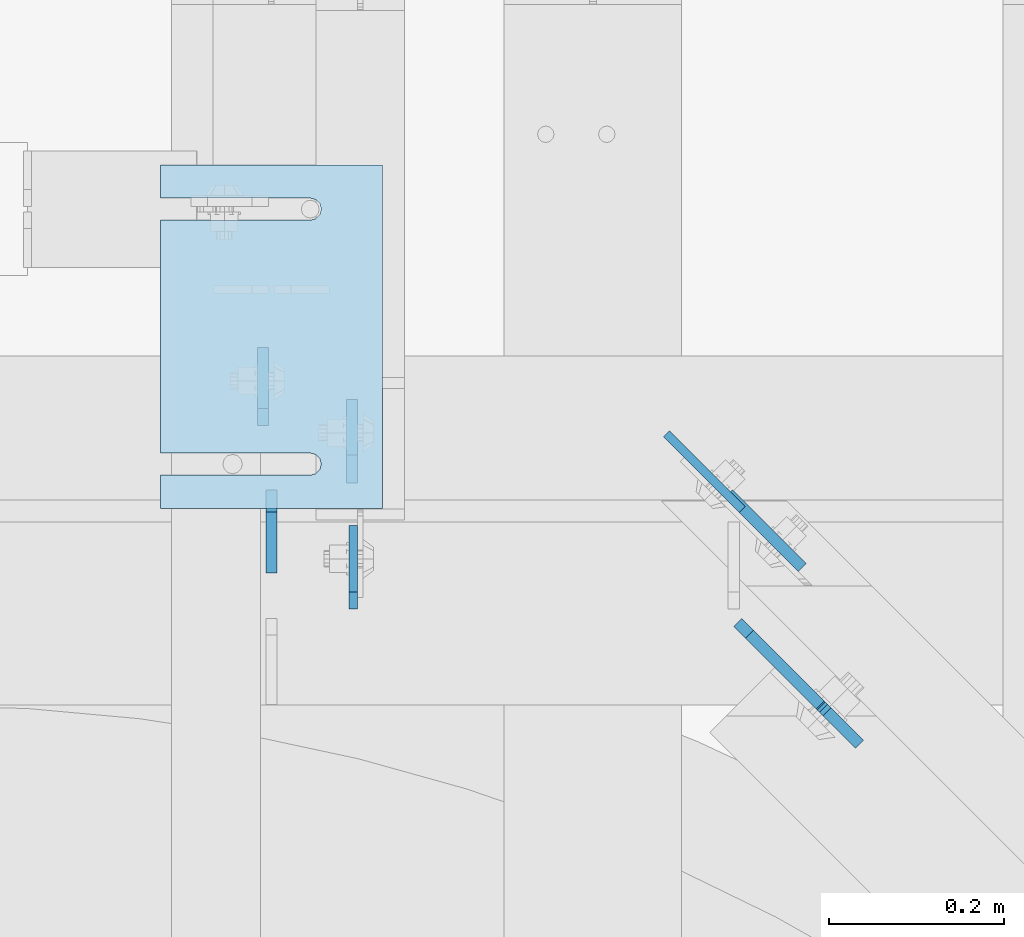
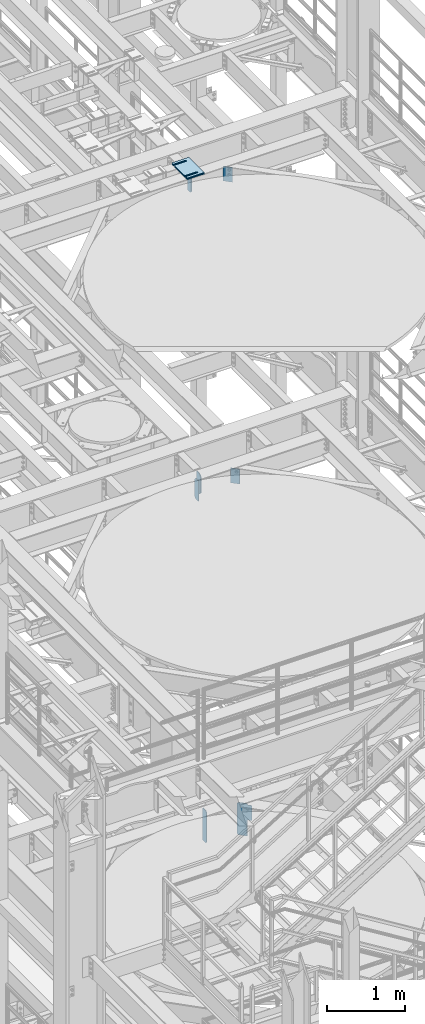
# One storey, part 1575 of 1876: 13 plates, 9 elements without a shape of their own.
"""IFC2X3 building model written with IfcOpenShell, lengths in millimetres."""

from ifc_helpers import new_model, si_unit, frame, origin_with_axes, place, context, subcontext, project, spatial, faceted_brep, material, type_object, element, aggregate, save


model = new_model("IFC2X3")

# Units and contexts
model_context = context("Model", 3, precision=1e-05, world=origin_with_axes())
body_context = subcontext(model_context, "Body", "Model", "MODEL_VIEW")
ifc_project = project(units=[si_unit("LENGTHUNIT", "METRE", prefix="MILLI"), si_unit("AREAUNIT", "SQUARE_METRE"), si_unit("VOLUMEUNIT", "CUBIC_METRE"), si_unit("MASSUNIT", "GRAM", prefix="KILO"), si_unit("TIMEUNIT", "SECOND"), si_unit("PLANEANGLEUNIT", "RADIAN"), si_unit("SOLIDANGLEUNIT", "STERADIAN"), si_unit("THERMODYNAMICTEMPERATUREUNIT", "DEGREE_CELSIUS"), si_unit("LUMINOUSINTENSITYUNIT", "LUMEN")], contexts=[model_context])

# Site, building, storey
site_placement = place(None, origin_with_axes())
site = spatial("IfcSite", under=ifc_project, at=site_placement, CompositionType="ELEMENT")
building_placement = place(site_placement, origin_with_axes())
building = spatial("IfcBuilding", under=site, at=building_placement, Name="Undefined", CompositionType="ELEMENT")
storey_placement = place(building_placement, origin_with_axes())
storey = spatial("IfcBuildingStorey", under=building, at=storey_placement, Name="Undefined", CompositionType="ELEMENT", Elevation=0.0)

# Assembly, plate
assembly_1_placement = place(storey_placement, origin_with_axes())
assembly_1 = element("IfcElementAssembly", 1, at=assembly_1_placement, inside=storey, Name="BEAM", AssemblyPlace="NOTDEFINED", PredefinedType="RIGID_FRAME")
ifc_material = material(Name="STEEL/A36")
plate_type_1 = type_object("IfcPlateType", PredefinedType="NOTDEFINED")
plate_1_placement = place(assembly_1_placement, frame((4919.66200008392, 704.254688, 7635.875), z_axis=(0.0, 0.0, 1.0), x_axis=(0.0, 1.0, 0.0)))
plate_1 = element("IfcPlate", 2, at=plate_1_placement, type_object=plate_type_1, material=ifc_material, Name="PLATE", context=body_context, shape_type="Brep", body=[
    faceted_brep([(0.0, -4.76249999999982, 19.0499992370605), (0.0, -4.76249999999982, 481.012500762939), (0.0, 4.76249999999982, 481.012500762939), (0.0, 4.76249999999982, 19.0499992370605), (19.0499992370605, -4.76249999999982, 500.0625), (19.0499992370605, 4.76249999999982, 500.0625), (95.25, -4.76249999999982, 500.0625), (95.25, 4.76249999999982, 500.0625), (95.25, -4.76249999999982, 0.0), (95.25, 4.76249999999982, 0.0), (19.0499992370605, -4.76249999999982, 0.0), (19.0499992370605, 4.76249999999982, 0.0)], [[[0, 1, 2, 3]], [[1, 4, 5, 2]], [[4, 6, 7, 5]], [[6, 8, 9, 7]], [[8, 10, 11, 9]], [[10, 0, 3, 11]], [[5, 7, 9, 11, 3, 2]], [[10, 8, 6, 4, 1, 0]]]),
])

assembly_2_placement = place(storey_placement, origin_with_axes())
assembly_2 = element("IfcElementAssembly", 3, at=assembly_2_placement, inside=storey, Name="BEAM", AssemblyPlace="NOTDEFINED", PredefinedType="RIGID_FRAME")
plate_type_2 = type_object("IfcPlateType", PredefinedType="NOTDEFINED")
plate_2_placement = place(assembly_2_placement, frame((4816.47517775661, 914.399999999455, 17681.575), z_axis=(0.0, 0.0, 1.0), x_axis=(0.0, 1.0, 0.0)))
plate_2 = element("IfcPlate", 4, at=plate_2_placement, type_object=plate_type_2, material=ifc_material, Name="PLATE", context=body_context, shape_type="Brep", body=[
    faceted_brep([(0.0, -6.35000000000196, 19.0499992370605), (0.0, -6.35000000000036, 271.462512969971), (0.0, 6.35000000000036, 271.462512969971), (0.0, 6.35000000000105, 19.0499992370605), (19.0499992370605, -6.35000000000036, 290.512512207031), (19.0499992370605, 6.35000000000036, 290.512512207031), (88.9000015258789, -6.35000000000036, 290.512512207031), (88.9000015258789, 6.35000000000036, 290.512512207031), (88.9000015258789, -6.34999999999991, 0.0), (88.9000015258789, 6.34999999999991, 0.0), (19.0499992370642, -6.35000000000105, 0.0), (19.0499992370633, 6.35000000000105, 0.0)], [[[0, 1, 2, 3]], [[1, 4, 5, 2]], [[4, 6, 7, 5]], [[6, 8, 9, 7]], [[8, 10, 11, 9]], [[10, 0, 3, 11]], [[5, 7, 9, 11, 3, 2]], [[10, 8, 6, 4, 1, 0]]]),
])

# Assembly, plates
assembly_3_placement = place(storey_placement, origin_with_axes())
assembly_3 = element("IfcElementAssembly", 5, at=assembly_3_placement, inside=storey, Name="BEAM", AssemblyPlace="NOTDEFINED", PredefinedType="RIGID_FRAME")
plate_type_3 = type_object("IfcPlateType", PredefinedType="NOTDEFINED")
plate_3_placement = place(assembly_3_placement, frame((4826.0, 745.33125, 12976.225), z_axis=(0.0, 0.0, 1.0), x_axis=(0.0, 1.0, 0.0)))
plate_3 = element("IfcPlate", 6, at=plate_3_placement, type_object=plate_type_3, material=ifc_material, Name="PLATE", context=body_context, shape_type="Brep", body=[
    faceted_brep([(0.0, -6.35000000000036, 0.0), (1.81898940354586e-12, -6.35000000000127, 317.5), (0.0, 6.35000000000036, 317.5), (0.0, 6.35000000000036, 0.0), (69.8500003814697, -6.34999999999991, 317.5), (69.8500003814697, 6.34999999999991, 317.5), (95.25, -6.34999999999991, 292.10000038147), (95.25, 6.34999999999991, 292.10000038147), (95.25, -6.34999999999991, 25.3999996185303), (95.25, 6.34999999999991, 25.3999996185303), (69.8500003814697, -6.34999999999991, 0.0), (69.8500003814697, 6.34999999999991, 0.0)], [[[0, 1, 2, 3]], [[1, 4, 5, 2]], [[4, 6, 7, 5]], [[6, 8, 9, 7]], [[8, 10, 11, 9]], [[10, 0, 3, 11]], [[5, 7, 9, 11, 3, 2]], [[10, 8, 6, 4, 1, 0]]]),
])
plate_4_placement = place(assembly_3_placement, frame((4918.07499990463, 848.51875, 12977.8125), z_axis=(0.0, 0.0, 1.0), x_axis=(0.0, 1.0, 0.0)))
plate_4 = element("IfcPlate", 7, at=plate_4_placement, type_object=plate_type_3, material=ifc_material, Name="PLATE", context=body_context, shape_type="Brep", body=[
    faceted_brep([(0.0, -6.34999999999991, 31.75), (-1.81898940354586e-12, -6.34999999999991, 284.162506103516), (1.81898940354586e-12, 6.35000000000173, 284.162506103516), (0.0, 6.34999999999991, 31.75), (31.7499999999927, -6.34999999999991, 315.912506103516), (31.7499999999982, 6.35000000000309, 315.912506103516), (95.25, -6.35000000000036, 315.912506103516), (95.25, 6.35000000000036, 315.912506103516), (95.25, -6.35000000000036, 0.0), (95.25, 6.35000000000036, 0.0), (31.75, -6.34999999999991, 0.0), (31.75, 6.34999999999991, 0.0)], [[[0, 1, 2, 3]], [[1, 4, 5, 2]], [[4, 6, 7, 5]], [[6, 8, 9, 7]], [[8, 10, 11, 9]], [[10, 0, 3, 11]], [[5, 7, 9, 11, 3, 2]], [[10, 8, 6, 4, 1, 0]]]),
])

# Plate
plate_type_4 = type_object("IfcPlateType", PredefinedType="NOTDEFINED")
plate_5_placement = place(assembly_1_placement, frame((5360.09011090052, 688.652059174589, 7653.3375), z_axis=(0.500000083934032, -0.499999915934031, 0.707106781279831), x_axis=(0.500000084065953, -0.499999916065956, -0.707106781093264)))
plate_5 = element("IfcPlate", 8, at=plate_5_placement, type_object=plate_type_4, material=ifc_material, Name="PLATE", context=body_context, shape_type="Brep", body=[
    faceted_brep([(0.0, -6.35000000000036, 0.0), (-327.779357909983, -6.34999999999945, 327.779357910018), (-327.779357909984, 6.34999999999945, 327.779357910018), (0.0, 6.35000000000036, 0.0), (-327.779357909974, -6.34999999999673, 354.720123290871), (-327.779357909975, 6.35000000000218, 354.72012329087), (-246.521087646294, -6.34999999997945, 435.978363036958), (-246.521087646295, 6.35000000001946, 435.978363036957), (-244.276026676376, -6.34999999997945, 433.733304414544), (-244.276026676377, 6.35000000001855, 433.733304414543), (-238.610784886918, -6.34999999997945, 429.947914446682), (-238.610784886918, 6.35000000001946, 429.947914446682), (-231.928178155422, -6.34999999997854, 428.618663148393), (-231.928178155423, 6.35000000001946, 428.618663148392), (-225.245571892809, -6.34999999997763, 429.947916803919), (-225.24557189281, 6.35000000001946, 429.947916803918), (-219.580331438615, -6.34999999997672, 433.73330877015), (-219.580331438616, 6.35000000002219, 433.73330877015), (-187.068817138485, -6.34999999997035, 466.244812011571), (-187.068817138485, 6.35000000002856, 466.244812011571), (-25.4242095946238, -6.34999999997035, 304.600189208904), (-25.4242095946247, 6.35000000002856, 304.600189208903), (-57.9357132390196, -6.34999999997672, 272.088696623216), (-57.9357132390196, 6.35000000002128, 272.088696623214), (-61.7211085739791, -6.34999999997763, 266.423453976015), (-61.72110857398, 6.35000000002128, 266.423453976014), (-63.0503630608664, -6.34999999997854, 259.740844111398), (-63.0503630608673, 6.35000000002037, 259.740844111397), (-61.7211097105192, -6.34999999997945, 253.058234020711), (-61.7211097105201, 6.35000000001946, 253.058234020711), (-57.935715339072, -6.34999999997945, 247.392990729717), (-57.9357153390729, 6.35000000001855, 247.392990729716), (108.199020385746, -6.34999999997854, 81.258255004881), (108.199020385745, 6.35000000001946, 81.258255004881), (26.9407691955512, -6.34999999999582, 4.54747350886464e-12), (26.9407691955503, 6.35000000000309, 3.63797880709171e-12)], [[[0, 1, 2, 3]], [[1, 4, 5, 2]], [[4, 6, 7, 5]], [[6, 8, 9, 7]], [[8, 10, 11, 9]], [[10, 12, 13, 11]], [[12, 14, 15, 13]], [[14, 16, 17, 15]], [[16, 18, 19, 17]], [[18, 20, 21, 19]], [[20, 22, 23, 21]], [[22, 24, 25, 23]], [[24, 26, 27, 25]], [[26, 28, 29, 27]], [[28, 30, 31, 29]], [[30, 32, 33, 31]], [[32, 34, 35, 33]], [[34, 0, 3, 35]], [[5, 7, 9, 11, 13, 15, 17, 19, 21, 23, 25, 27, 29, 31, 33, 35, 3, 2]], [[34, 32, 30, 28, 26, 24, 22, 20, 18, 16, 14, 12, 10, 8, 6, 4, 1, 0]]]),
])

aggregate(assembly_1, [plate_5, plate_1])

# Assembly, plate
assembly_4_placement = place(storey_placement, origin_with_axes())
assembly_4 = element("IfcElementAssembly", 9, at=assembly_4_placement, inside=storey, Name="SHIM PLATE", AssemblyPlace="NOTDEFINED", PredefinedType="RIGID_FRAME")
plate_type_5 = type_object("IfcPlateType", PredefinedType="NOTDEFINED")
plate_6_placement = place(assembly_4_placement, frame((4952.9989117589, 819.151560067805, 18007.0115), z_axis=(-1.0, 0.0, 0.0), x_axis=(0.0, 1.0, 0.0)))
plate_6 = element("IfcPlate", 10, at=plate_6_placement, type_object=plate_type_5, material=ifc_material, Name="SHIM PLATE", context=body_context, shape_type="Brep", body=[
    faceted_brep([(38.0954210666328, -1.58750000000146, 253.999557495103), (38.0976431969724, -1.58750000000146, 82.6182312417654), (38.0976431969724, 1.58750000000146, 82.6182312417654), (38.0954210666328, 1.58750000000146, 253.999557495103), (39.7991131045027, -1.58750000000146, 76.2682279470096), (39.7991131045027, 1.58750000000146, 76.2682279470096), (44.4476316136985, -1.58750000000146, 71.6196994315187), (44.4476316136985, 1.58750000000146, 71.6196994315187), (50.7976312458977, -1.58750000000146, 69.9182158551362), (50.7976312458977, 1.58750000000146, 69.9182158551362), (57.1476337740625, -1.58750000000146, 71.6196886236189), (57.1476337740625, 1.58750000000146, 71.6196886236189), (61.7961601951824, -1.58750000000146, 76.2682092271793), (61.7961601951824, 1.58750000000146, 76.2682092271793), (63.497640910601, -1.58750000000146, 82.6182096259718), (63.497640910601, 1.58750000000146, 82.6182096259718), (63.4954187799489, -1.58750000000146, 253.999557267866), (63.4954187799489, 1.58750000000146, 253.999557495093), (9.09494701772928e-13, -1.58750000000146, 4.54747350886464e-13), (1.89071320164658e-05, -1.58750000000146, 253.999557495117), (1.89071320164658e-05, 1.58750000000146, 253.999557495117), (9.09494701772928e-13, 1.58750000000146, 4.54747350886464e-13), (393.698486328125, -1.58750000000146, -1.40062184073031e-10), (393.698486328125, 1.58750000000146, -1.40062184073031e-10), (393.698516845714, -1.58750000000146, 253.999557494967), (393.698516845714, 1.58750000000146, 253.999557494967), (355.593905292273, 1.58750000000146, 253.999557494981), (355.593905292273, -1.58750000000146, 253.999558194833), (355.596127251301, 1.58750000000146, 82.6182258117283), (355.596127251301, -1.58750000000146, 82.6182258117283), (353.894652887411, 1.58750000000146, 76.2682211679371), (353.894652887411, -1.58750000000146, 76.2682211679371), (349.246128913514, 1.58750000000146, 71.6196946431969), (349.246128913514, -1.58750000000146, 71.6196946431969), (342.896125203397, 1.58750000000146, 69.9182167947934), (342.896125203397, -1.58750000000146, 69.9182167947934), (336.546122348359, 1.58750000000146, 71.6196978343955), (336.546122348359, -1.58750000000146, 71.6196978343955), (331.897600710579, 1.58750000000146, 76.2682266952543), (331.897600710579, -1.58750000000146, 76.2682266952543), (330.196129537885, 1.58750000000146, 82.6182321941214), (330.196129537885, -1.58750000000146, 82.6182321941214), (330.193907578964, -1.58750000000146, 253.999557494991), (330.193907578964, 1.58750000000146, 253.999557494991)], [[[0, 1, 2, 3]], [[4, 5, 2, 1]], [[6, 7, 5, 4]], [[8, 9, 7, 6]], [[10, 11, 9, 8]], [[12, 13, 11, 10]], [[14, 15, 13, 12]], [[16, 17, 15, 14]], [[18, 19, 20, 21]], [[22, 18, 21, 23]], [[24, 22, 23, 25]], [[24, 25, 26, 27]], [[27, 26, 28, 29]], [[29, 28, 30, 31]], [[31, 30, 32, 33]], [[33, 32, 34, 35]], [[35, 34, 36, 37]], [[37, 36, 38, 39]], [[39, 38, 40, 41]], [[42, 41, 40, 43]], [[12, 10, 8, 6, 4, 1, 0, 19, 18, 22, 24, 27, 29, 31, 33, 35, 37, 39, 41, 42, 16, 14]], [[20, 19, 0, 3]], [[43, 40, 38, 36, 34, 32, 30, 28, 26, 25, 23, 21, 20, 3, 2, 5, 7, 9, 11, 13, 15, 17]], [[42, 43, 17, 16]]]),
])
aggregate(assembly_4, [plate_6])

assembly_5_placement = place(storey_placement, origin_with_axes())
assembly_5 = element("IfcElementAssembly", 11, at=assembly_5_placement, inside=storey, Name="SHIM PLATE", AssemblyPlace="NOTDEFINED", PredefinedType="RIGID_FRAME")
plate_7_placement = place(assembly_5_placement, frame((4952.99891175908, 819.151560067807, 18003.8365), z_axis=(-1.0, 0.0, 0.0), x_axis=(0.0, 1.0, 0.0)))
plate_7 = element("IfcPlate", 12, at=plate_7_placement, type_object=plate_type_5, material=ifc_material, Name="SHIM PLATE", context=body_context, shape_type="Brep", body=[
    faceted_brep([(38.0954210666328, -1.58750000000146, 253.999557495103), (38.0976431969724, -1.58750000000146, 82.6182312417654), (38.0976431969724, 1.58750000000146, 82.6182312417654), (38.0954210666328, 1.58750000000146, 253.999557495103), (39.7991131045027, -1.58750000000146, 76.2682279470096), (39.7991131045027, 1.58750000000146, 76.2682279470096), (44.4476316136985, -1.58750000000146, 71.6196994315187), (44.4476316136985, 1.58750000000146, 71.6196994315187), (50.7976312458977, -1.58750000000146, 69.9182158551362), (50.7976312458977, 1.58750000000146, 69.9182158551362), (57.1476337740625, -1.58750000000146, 71.6196886236189), (57.1476337740625, 1.58750000000146, 71.6196886236189), (61.7961601951824, -1.58750000000146, 76.2682092271793), (61.7961601951824, 1.58750000000146, 76.2682092271793), (63.497640910601, -1.58750000000146, 82.6182096259718), (63.497640910601, 1.58750000000146, 82.6182096259718), (63.4954187799489, -1.58750000000146, 253.999557267866), (63.4954187799489, 1.58750000000146, 253.999557495093), (9.09494701772928e-13, -1.58750000000146, 4.54747350886464e-13), (1.89071320164658e-05, -1.58750000000146, 253.999557495117), (1.89071320164658e-05, 1.58750000000146, 253.999557495117), (9.09494701772928e-13, 1.58750000000146, 4.54747350886464e-13), (393.698486328125, -1.58750000000146, -1.40062184073031e-10), (393.698486328125, 1.58750000000146, -1.40062184073031e-10), (393.698516845714, -1.58750000000146, 253.999557494967), (393.698516845714, 1.58750000000146, 253.999557494967), (355.593905292273, 1.58750000000146, 253.999557494981), (355.593905292273, -1.58750000000146, 253.999558194833), (355.596127251301, 1.58750000000146, 82.6182258117283), (355.596127251301, -1.58750000000146, 82.6182258117283), (353.894652887411, 1.58750000000146, 76.2682211679371), (353.894652887411, -1.58750000000146, 76.2682211679371), (349.246128913514, 1.58750000000146, 71.6196946431969), (349.246128913514, -1.58750000000146, 71.6196946431969), (342.896125203397, 1.58750000000146, 69.9182167947934), (342.896125203397, -1.58750000000146, 69.9182167947934), (336.546122348359, 1.58750000000146, 71.6196978343955), (336.546122348359, -1.58750000000146, 71.6196978343955), (331.897600710579, 1.58750000000146, 76.2682266952543), (331.897600710579, -1.58750000000146, 76.2682266952543), (330.196129537885, 1.58750000000146, 82.6182321941214), (330.196129537885, -1.58750000000146, 82.6182321941214), (330.193907578964, -1.58750000000146, 253.999557494991), (330.193907578964, 1.58750000000146, 253.999557494991)], [[[0, 1, 2, 3]], [[4, 5, 2, 1]], [[6, 7, 5, 4]], [[8, 9, 7, 6]], [[10, 11, 9, 8]], [[12, 13, 11, 10]], [[14, 15, 13, 12]], [[16, 17, 15, 14]], [[18, 19, 20, 21]], [[22, 18, 21, 23]], [[24, 22, 23, 25]], [[24, 25, 26, 27]], [[27, 26, 28, 29]], [[29, 28, 30, 31]], [[31, 30, 32, 33]], [[33, 32, 34, 35]], [[35, 34, 36, 37]], [[37, 36, 38, 39]], [[39, 38, 40, 41]], [[42, 41, 40, 43]], [[12, 10, 8, 6, 4, 1, 0, 19, 18, 22, 24, 27, 29, 31, 33, 35, 37, 39, 41, 42, 16, 14]], [[20, 19, 0, 3]], [[43, 40, 38, 36, 34, 32, 30, 28, 26, 25, 23, 21, 20, 3, 2, 5, 7, 9, 11, 13, 15, 17]], [[42, 43, 17, 16]]]),
])
aggregate(assembly_5, [plate_7])

assembly_6_placement = place(storey_placement, origin_with_axes())
assembly_6 = element("IfcElementAssembly", 13, at=assembly_6_placement, inside=storey, Name="SHIM PLATE", AssemblyPlace="NOTDEFINED", PredefinedType="RIGID_FRAME")
plate_type_6 = type_object("IfcPlateType", PredefinedType="NOTDEFINED")
plate_8_placement = place(assembly_6_placement, frame((4952.99891175873, 819.151560067803, 18009.3925), z_axis=(-1.0, 0.0, 0.0), x_axis=(0.0, 1.0, 0.0)))
plate_8 = element("IfcPlate", 14, at=plate_8_placement, type_object=plate_type_6, material=ifc_material, Name="SHIM PLATE", context=body_context, shape_type="Brep", body=[
    faceted_brep([(38.0954210666328, -0.793499999999767, 253.999557495103), (38.0976431969724, -0.793499999999767, 82.6182312417654), (38.0976431969724, 0.793499999999767, 82.6182312417654), (38.0954210666328, 0.793499999999767, 253.999557495103), (39.7991131045027, -0.793499999999767, 76.2682279470096), (39.7991131045027, 0.793499999999767, 76.2682279470096), (44.4476316136985, -0.793499999999767, 71.6196994315187), (44.4476316136985, 0.793499999999767, 71.6196994315187), (50.7976312458977, -0.793499999999767, 69.9182158551362), (50.7976312458977, 0.793499999999767, 69.9182158551362), (57.1476337740625, -0.793499999999767, 71.6196886236189), (57.1476337740625, 0.793499999999767, 71.6196886236189), (61.7961601951824, -0.793499999999767, 76.2682092271793), (61.7961601951824, 0.793499999999767, 76.2682092271793), (63.497640910601, -0.793499999999767, 82.6182096259718), (63.497640910601, 0.793499999999767, 82.6182096259718), (63.4954187799489, -0.793499999999767, 253.999557267866), (63.4954187799489, 0.793499999999767, 253.999557495093), (9.09494701772928e-13, -0.793499999999767, 0.0), (1.89070156011439e-05, -0.793499999999767, 253.999557495117), (1.89070156011439e-05, 0.793499999999767, 253.999557495117), (9.09494701772928e-13, 0.793499999999767, 0.0), (393.698486328125, -0.793499999999767, -1.39152689371258e-10), (393.698486328125, 0.793499999999767, -1.39152689371258e-10), (393.698516845714, -0.793499999999767, 253.999557494967), (393.698516845714, 0.793499999999767, 253.999557494967), (355.593905292273, 0.793499999999767, 253.999557494981), (355.593905292273, -0.793499999999767, 253.999558194833), (355.596127251301, 0.793499999999767, 82.6182258117283), (355.596127251301, -0.793499999999767, 82.6182258117283), (353.894652887411, 0.793499999999767, 76.2682211679371), (353.894652887411, -0.793499999999767, 76.2682211679371), (349.246128913514, 0.793499999999767, 71.6196946431969), (349.246128913514, -0.793499999999767, 71.6196946431969), (342.896125203397, 0.793499999999767, 69.9182167947934), (342.896125203397, -0.793499999999767, 69.9182167947934), (336.546122348359, 0.793499999999767, 71.6196978343955), (336.546122348359, -0.793499999999767, 71.6196978343955), (331.897600710579, 0.793499999999767, 76.2682266952543), (331.897600710579, -0.793499999999767, 76.2682266952543), (330.196129537885, 0.793499999999767, 82.6182321941214), (330.196129537885, -0.793499999999767, 82.6182321941214), (330.193907578964, -0.793499999999767, 253.999557494991), (330.193907578964, 0.793499999999767, 253.999557494991)], [[[0, 1, 2, 3]], [[4, 5, 2, 1]], [[6, 7, 5, 4]], [[8, 9, 7, 6]], [[10, 11, 9, 8]], [[12, 13, 11, 10]], [[14, 15, 13, 12]], [[16, 17, 15, 14]], [[18, 19, 20, 21]], [[22, 18, 21, 23]], [[24, 22, 23, 25]], [[24, 25, 26, 27]], [[27, 26, 28, 29]], [[29, 28, 30, 31]], [[31, 30, 32, 33]], [[33, 32, 34, 35]], [[35, 34, 36, 37]], [[37, 36, 38, 39]], [[39, 38, 40, 41]], [[42, 41, 40, 43]], [[12, 10, 8, 6, 4, 1, 0, 19, 18, 22, 24, 27, 29, 31, 33, 35, 37, 39, 41, 42, 16, 14]], [[20, 19, 0, 3]], [[43, 40, 38, 36, 34, 32, 30, 28, 26, 25, 23, 21, 20, 3, 2, 5, 7, 9, 11, 13, 15, 17]], [[42, 43, 17, 16]]]),
])
aggregate(assembly_6, [plate_8])

assembly_7_placement = place(storey_placement, origin_with_axes())
assembly_7 = element("IfcElementAssembly", 15, at=assembly_7_placement, inside=storey, Name="SHIM PLATE", AssemblyPlace="NOTDEFINED", PredefinedType="RIGID_FRAME")
plate_type_7 = type_object("IfcPlateType", PredefinedType="NOTDEFINED")
plate_9_placement = place(assembly_7_placement, frame((4952.99891175926, 819.151560067808, 17999.868), z_axis=(-1.0, 0.0, 0.0), x_axis=(0.0, 1.0, 0.0)))
plate_9 = element("IfcPlate", 16, at=plate_9_placement, type_object=plate_type_7, material=ifc_material, Name="SHIM PLATE", context=body_context, shape_type="Brep", body=[
    faceted_brep([(38.0954210666329, -2.38100000000122, 253.999557495103), (38.0976431969724, -2.38100000000122, 82.6182312417654), (38.0976431969724, 2.38100000000122, 82.6182312417654), (38.0954210666329, 2.38100000000122, 253.999557495103), (39.7991131045027, -2.38100000000122, 76.2682279470096), (39.7991131045027, 2.38100000000122, 76.2682279470096), (44.4476316136985, -2.38100000000122, 71.6196994315187), (44.4476316136985, 2.38100000000122, 71.6196994315187), (50.7976312458977, -2.38100000000122, 69.9182158551362), (50.7976312458977, 2.38100000000122, 69.9182158551362), (57.1476337740625, -2.38100000000122, 71.6196886236189), (57.1476337740625, 2.38100000000122, 71.6196886236189), (61.7961601951824, -2.38100000000122, 76.2682092271793), (61.7961601951824, 2.38100000000122, 76.2682092271793), (63.497640910601, -2.38100000000122, 82.6182096259718), (63.497640910601, 2.38100000000122, 82.6182096259718), (63.4954187799489, -2.38100000000122, 253.999557267866), (63.4954187799489, 2.38100000000122, 253.999557495093), (0.0, -2.38100000000122, 4.54747350886464e-13), (1.89072484317876e-05, -2.38100000000122, 253.999557495117), (1.89072484317876e-05, 2.38100000000122, 253.999557495117), (0.0, 2.38100000000122, 4.54747350886464e-13), (393.698486328125, -2.38100000000122, -1.40971678774804e-10), (393.698486328125, 2.38100000000122, -1.40971678774804e-10), (393.698516845714, -2.38100000000122, 253.999557494967), (393.698516845714, 2.38100000000122, 253.999557494967), (355.593905292273, 2.38100000000122, 253.999557494981), (355.593905292273, -2.38100000000122, 253.999558194833), (355.596127251301, 2.38100000000122, 82.6182258117283), (355.596127251301, -2.38100000000122, 82.6182258117283), (353.894652887411, 2.38100000000122, 76.2682211679371), (353.894652887411, -2.38100000000122, 76.2682211679371), (349.246128913514, 2.38100000000122, 71.6196946431969), (349.246128913514, -2.38100000000122, 71.6196946431969), (342.896125203397, 2.38100000000122, 69.9182167947934), (342.896125203397, -2.38100000000122, 69.9182167947934), (336.546122348359, 2.38100000000122, 71.6196978343955), (336.546122348359, -2.38100000000122, 71.6196978343955), (331.897600710579, 2.38100000000122, 76.2682266952543), (331.897600710579, -2.38100000000122, 76.2682266952543), (330.196129537885, 2.38100000000122, 82.6182321941214), (330.196129537885, -2.38100000000122, 82.6182321941214), (330.193907578964, -2.38100000000122, 253.999557494991), (330.193907578964, 2.38100000000122, 253.999557494991)], [[[0, 1, 2, 3]], [[4, 5, 2, 1]], [[6, 7, 5, 4]], [[8, 9, 7, 6]], [[10, 11, 9, 8]], [[12, 13, 11, 10]], [[14, 15, 13, 12]], [[16, 17, 15, 14]], [[18, 19, 20, 21]], [[22, 18, 21, 23]], [[24, 22, 23, 25]], [[24, 25, 26, 27]], [[27, 26, 28, 29]], [[29, 28, 30, 31]], [[31, 30, 32, 33]], [[33, 32, 34, 35]], [[35, 34, 36, 37]], [[37, 36, 38, 39]], [[39, 38, 40, 41]], [[42, 41, 40, 43]], [[12, 10, 8, 6, 4, 1, 0, 19, 18, 22, 24, 27, 29, 31, 33, 35, 37, 39, 41, 42, 16, 14]], [[20, 19, 0, 3]], [[43, 40, 38, 36, 34, 32, 30, 28, 26, 25, 23, 21, 20, 3, 2, 5, 7, 9, 11, 13, 15, 17]], [[42, 43, 17, 16]]]),
])
aggregate(assembly_7, [plate_9])

assembly_8_placement = place(storey_placement, origin_with_axes())
assembly_8 = element("IfcElementAssembly", 17, at=assembly_8_placement, inside=storey, Name="SHIM PLATE", AssemblyPlace="NOTDEFINED", PredefinedType="RIGID_FRAME")
plate_10_placement = place(assembly_8_placement, frame((4952.99891175944, 819.151560067808, 17995.106), z_axis=(-1.0, 0.0, 0.0), x_axis=(0.0, 1.0, 0.0)))
plate_10 = element("IfcPlate", 18, at=plate_10_placement, type_object=plate_type_7, material=ifc_material, Name="SHIM PLATE", context=body_context, shape_type="Brep", body=[
    faceted_brep([(38.0954210666329, -2.38100000000122, 253.999557495103), (38.0976431969724, -2.38100000000122, 82.6182312417654), (38.0976431969724, 2.38100000000122, 82.6182312417654), (38.0954210666329, 2.38100000000122, 253.999557495103), (39.7991131045027, -2.38100000000122, 76.2682279470096), (39.7991131045027, 2.38100000000122, 76.2682279470096), (44.4476316136985, -2.38100000000122, 71.6196994315187), (44.4476316136985, 2.38100000000122, 71.6196994315187), (50.7976312458977, -2.38100000000122, 69.9182158551362), (50.7976312458977, 2.38100000000122, 69.9182158551362), (57.1476337740625, -2.38100000000122, 71.6196886236189), (57.1476337740625, 2.38100000000122, 71.6196886236189), (61.7961601951824, -2.38100000000122, 76.2682092271793), (61.7961601951824, 2.38100000000122, 76.2682092271793), (63.497640910601, -2.38100000000122, 82.6182096259718), (63.497640910601, 2.38100000000122, 82.6182096259718), (63.4954187799489, -2.38100000000122, 253.999557267866), (63.4954187799489, 2.38100000000122, 253.999557495093), (0.0, -2.38100000000122, 4.54747350886464e-13), (1.89072484317876e-05, -2.38100000000122, 253.999557495117), (1.89072484317876e-05, 2.38100000000122, 253.999557495117), (0.0, 2.38100000000122, 4.54747350886464e-13), (393.698486328125, -2.38100000000122, -1.40971678774804e-10), (393.698486328125, 2.38100000000122, -1.40971678774804e-10), (393.698516845714, -2.38100000000122, 253.999557494967), (393.698516845714, 2.38100000000122, 253.999557494967), (355.593905292273, 2.38100000000122, 253.999557494981), (355.593905292273, -2.38100000000122, 253.999558194833), (355.596127251301, 2.38100000000122, 82.6182258117283), (355.596127251301, -2.38100000000122, 82.6182258117283), (353.894652887411, 2.38100000000122, 76.2682211679371), (353.894652887411, -2.38100000000122, 76.2682211679371), (349.246128913514, 2.38100000000122, 71.6196946431969), (349.246128913514, -2.38100000000122, 71.6196946431969), (342.896125203397, 2.38100000000122, 69.9182167947934), (342.896125203397, -2.38100000000122, 69.9182167947934), (336.546122348359, 2.38100000000122, 71.6196978343955), (336.546122348359, -2.38100000000122, 71.6196978343955), (331.897600710579, 2.38100000000122, 76.2682266952543), (331.897600710579, -2.38100000000122, 76.2682266952543), (330.196129537885, 2.38100000000122, 82.6182321941214), (330.196129537885, -2.38100000000122, 82.6182321941214), (330.193907578964, -2.38100000000122, 253.999557494991), (330.193907578964, 2.38100000000122, 253.999557494991)], [[[0, 1, 2, 3]], [[4, 5, 2, 1]], [[6, 7, 5, 4]], [[8, 9, 7, 6]], [[10, 11, 9, 8]], [[12, 13, 11, 10]], [[14, 15, 13, 12]], [[16, 17, 15, 14]], [[18, 19, 20, 21]], [[22, 18, 21, 23]], [[24, 22, 23, 25]], [[24, 25, 26, 27]], [[27, 26, 28, 29]], [[29, 28, 30, 31]], [[31, 30, 32, 33]], [[33, 32, 34, 35]], [[35, 34, 36, 37]], [[37, 36, 38, 39]], [[39, 38, 40, 41]], [[42, 41, 40, 43]], [[12, 10, 8, 6, 4, 1, 0, 19, 18, 22, 24, 27, 29, 31, 33, 35, 37, 39, 41, 42, 16, 14]], [[20, 19, 0, 3]], [[43, 40, 38, 36, 34, 32, 30, 28, 26, 25, 23, 21, 20, 3, 2, 5, 7, 9, 11, 13, 15, 17]], [[42, 43, 17, 16]]]),
])
aggregate(assembly_8, [plate_10])

assembly_9_placement = place(storey_placement, origin_with_axes())
assembly_9 = element("IfcElementAssembly", 19, at=assembly_9_placement, inside=storey, Name="SHIM PLATE", AssemblyPlace="NOTDEFINED", PredefinedType="RIGID_FRAME")
plate_type_8 = type_object("IfcPlateType", PredefinedType="NOTDEFINED")
plate_11_placement = place(assembly_9_placement, frame((4952.99891175962, 819.151560067806, 17987.9625), z_axis=(-1.0, 0.0, 0.0), x_axis=(0.0, 1.0, 0.0)))
plate_11 = element("IfcPlate", 20, at=plate_11_placement, type_object=plate_type_8, material=ifc_material, Name="SHIM PLATE", context=body_context, shape_type="Brep", body=[
    faceted_brep([(38.0954210666328, -4.76250000000073, 253.999557495103), (38.0976431969724, -4.76250000000073, 82.6182312417654), (38.0976431969724, 4.76250000000073, 82.6182312417654), (38.0954210666328, 4.76250000000073, 253.999557495103), (39.7991131045027, -4.76250000000073, 76.2682279470096), (39.7991131045027, 4.76250000000073, 76.2682279470096), (44.4476316136985, -4.76250000000073, 71.6196994315187), (44.4476316136985, 4.76250000000073, 71.6196994315187), (50.7976312458977, -4.76250000000073, 69.9182158551362), (50.7976312458977, 4.76250000000073, 69.9182158551362), (57.1476337740625, -4.76250000000073, 71.6196886236189), (57.1476337740625, 4.76250000000073, 71.6196886236189), (61.7961601951824, -4.76250000000073, 76.2682092271793), (61.7961601951824, 4.76250000000073, 76.2682092271793), (63.497640910601, -4.76250000000073, 82.6182096259718), (63.497640910601, 4.76250000000073, 82.6182096259718), (63.4954187799489, -4.76250000000073, 253.999557267866), (63.4954187799489, 4.76250000000073, 253.999557495093), (0.0, -4.76249999999982, 0.0), (1.89073648471094e-05, -4.76250000000073, 253.999557495117), (1.89073648471094e-05, 4.76250000000073, 253.999557495117), (0.0, 4.76249999999982, 0.0), (393.698486328125, -4.76250000000073, -1.41881173476577e-10), (393.698486328125, 4.76250000000073, -1.41881173476577e-10), (393.698516845714, -4.76250000000073, 253.999557494967), (393.698516845714, 4.76250000000073, 253.999557494967), (355.593905292273, 4.76250000000073, 253.999557494981), (355.593905292273, -4.76250000000073, 253.999558194833), (355.596127251301, 4.76250000000073, 82.6182258117283), (355.596127251301, -4.76250000000073, 82.6182258117283), (353.894652887411, 4.76250000000073, 76.2682211679371), (353.894652887411, -4.76250000000073, 76.2682211679371), (349.246128913514, 4.76250000000073, 71.6196946431969), (349.246128913514, -4.76250000000073, 71.6196946431969), (342.896125203397, 4.76250000000073, 69.9182167947934), (342.896125203397, -4.76250000000073, 69.9182167947934), (336.546122348359, 4.76250000000073, 71.6196978343955), (336.546122348359, -4.76250000000073, 71.6196978343955), (331.897600710579, 4.76250000000073, 76.2682266952543), (331.897600710579, -4.76250000000073, 76.2682266952543), (330.196129537885, 4.76250000000073, 82.6182321941214), (330.196129537885, -4.76250000000073, 82.6182321941214), (330.193907578964, -4.76250000000073, 253.999557494991), (330.193907578964, 4.76250000000073, 253.999557494991)], [[[0, 1, 2, 3]], [[4, 5, 2, 1]], [[6, 7, 5, 4]], [[8, 9, 7, 6]], [[10, 11, 9, 8]], [[12, 13, 11, 10]], [[14, 15, 13, 12]], [[16, 17, 15, 14]], [[18, 19, 20, 21]], [[22, 18, 21, 23]], [[24, 22, 23, 25]], [[24, 25, 26, 27]], [[27, 26, 28, 29]], [[29, 28, 30, 31]], [[31, 30, 32, 33]], [[33, 32, 34, 35]], [[35, 34, 36, 37]], [[37, 36, 38, 39]], [[39, 38, 40, 41]], [[42, 41, 40, 43]], [[12, 10, 8, 6, 4, 1, 0, 19, 18, 22, 24, 27, 29, 31, 33, 35, 37, 39, 41, 42, 16, 14]], [[20, 19, 0, 3]], [[43, 40, 38, 36, 34, 32, 30, 28, 26, 25, 23, 21, 20, 3, 2, 5, 7, 9, 11, 13, 15, 17]], [[42, 43, 17, 16]]]),
])
aggregate(assembly_9, [plate_11])

# Plate
plate_type_9 = type_object("IfcPlateType", PredefinedType="NOTDEFINED")
plate_12_placement = place(assembly_2_placement, frame((5278.48486663161, 904.682403962482, 17945.1), z_axis=(0.707106781186547, -0.707106781186548, 0.0), x_axis=(0.0, 0.0, -1.0)))
plate_12 = element("IfcPlate", 21, at=plate_12_placement, type_object=plate_type_9, material=ifc_material, Name="PLATE", context=body_context, shape_type="Brep", body=[
    faceted_brep([(0.0, -4.76249999999982, 0.0), (0.0, -4.76249999998612, 122.735511779807), (0.0, 4.76250000001534, 122.735511779805), (0.0, 4.76249999999982, 0.0), (228.600006103516, -4.76249999998612, 122.735511779807), (228.600006103516, 4.76250000001534, 122.735511779805), (228.600006103516, -4.76250000000073, 0.0), (228.600006103516, 4.76250000000073, 0.0)], [[[0, 1, 2, 3]], [[1, 4, 5, 2]], [[4, 6, 7, 5]], [[6, 0, 3, 7]], [[5, 7, 3, 2]], [[6, 4, 1, 0]]]),
])

aggregate(assembly_2, [plate_2, plate_12])

plate_type_10 = type_object("IfcPlateType", PredefinedType="NOTDEFINED")
plate_13_placement = place(assembly_3_placement, frame((5349.57645635392, 836.091121298212, 13258.8), z_axis=(0.707106781186547, -0.707106781186548, 0.0), x_axis=(0.0, 0.0, -1.0)))
plate_13 = element("IfcPlate", 22, at=plate_13_placement, type_object=plate_type_10, material=ifc_material, Name="PLATE", context=body_context, shape_type="Brep", body=[
    faceted_brep([(0.0, -6.35000000000036, 0.0), (0.0, -6.35000000004948, 119.560508728048), (0.0, 6.34999999994943, 119.560508728049), (0.0, 6.35000000000036, 0.0), (228.600006103516, -6.35000000004948, 119.560508728048), (228.600006103516, 6.34999999994943, 119.560508728049), (228.600006103516, -6.34999999999854, 0.0), (228.600006103516, 6.34999999999854, 0.0)], [[[0, 1, 2, 3]], [[1, 4, 5, 2]], [[4, 6, 7, 5]], [[6, 0, 3, 7]], [[5, 7, 3, 2]], [[6, 4, 1, 0]]]),
])

aggregate(assembly_3, [plate_3, plate_13, plate_4])

save(model, "model.ifc")
